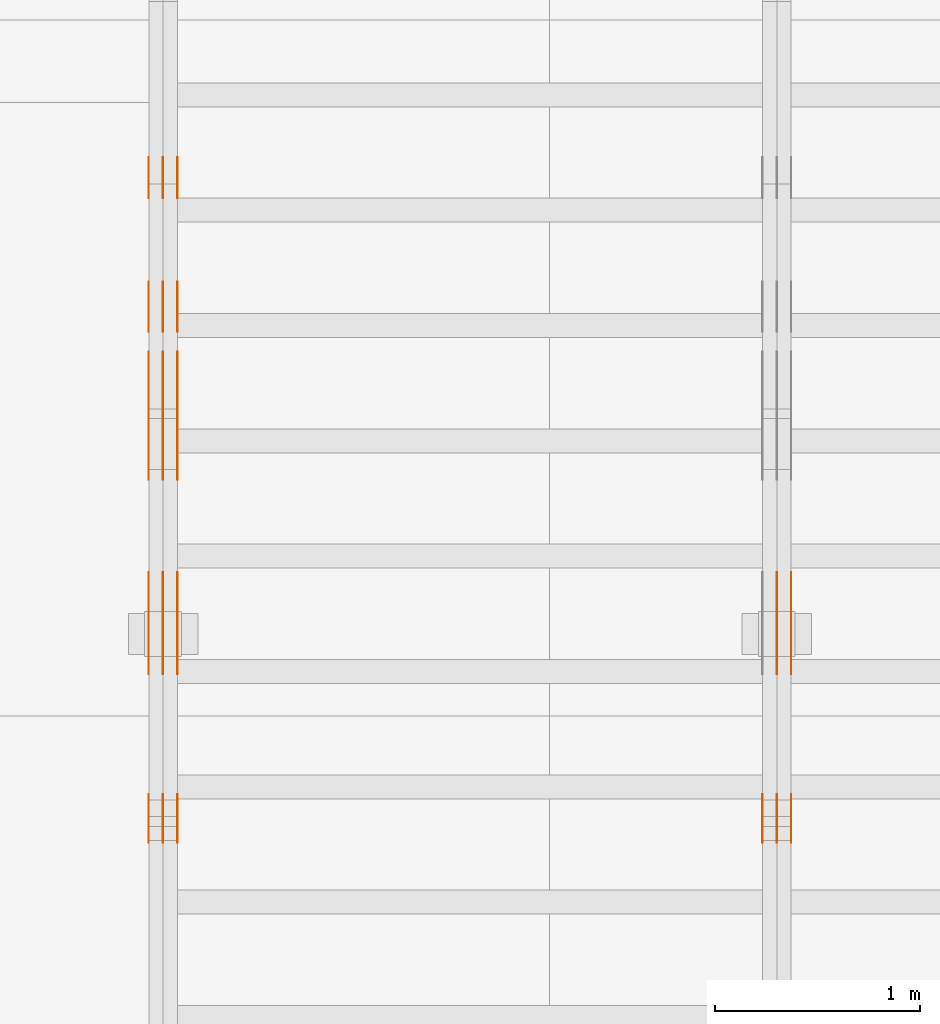
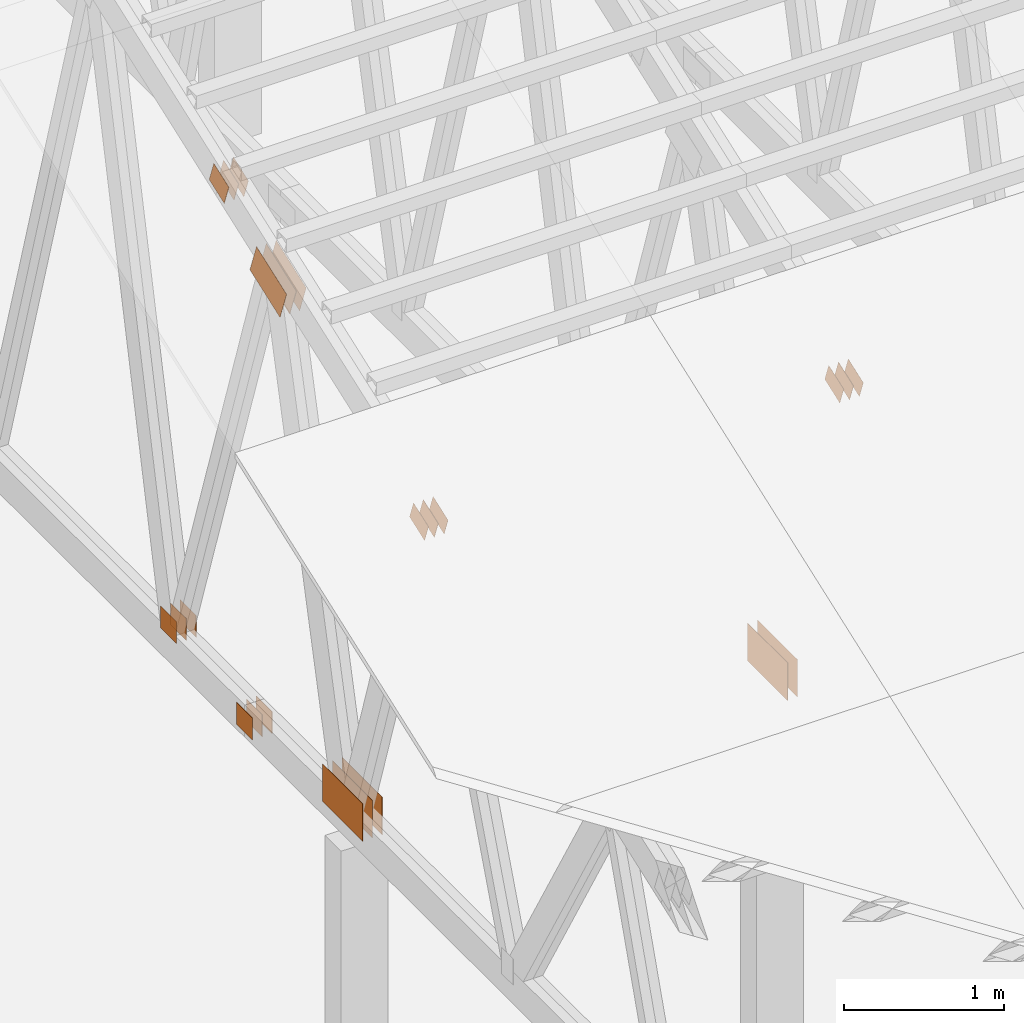
# One storey, part 76 of 189: 31 proxies.
"""IFC2X3 building model written with IfcOpenShell, lengths in millimetres."""

from ifc_helpers import new_model, entity, si_unit, converted_unit, derived_unit, direction, frame, frame_2d, origin, origin_2d_with_axis, place, context, subcontext, project, spatial, polyline, rectangle, outline, extrude, source, transform, mapped, material, type_object, type_shapes, element, save


model = new_model("IFC2X3")

# Units and contexts
model_context = context("Model", 3, precision=0.01, world=origin(), true_north=direction((6.12303176911189e-17, 1.0)))
body_context = subcontext(model_context, "Body", "Model", "MODEL_VIEW")
ifc_project = project(units=[si_unit("LENGTHUNIT", "METRE", prefix="MILLI"), si_unit("AREAUNIT", "SQUARE_METRE"), si_unit("VOLUMEUNIT", "CUBIC_METRE"), converted_unit("PLANEANGLEUNIT", "DEGREE", entity("IfcRatioMeasure", 0.0174532925199433), si_unit("PLANEANGLEUNIT", "RADIAN"), dimensions=[0, 0, 0, 0, 0, 0, 0]), si_unit("MASSUNIT", "GRAM", prefix="KILO"), derived_unit("MASSDENSITYUNIT", [(si_unit("MASSUNIT", "GRAM", prefix="KILO"), 1), (si_unit("LENGTHUNIT", "METRE"), -3)]), si_unit("TIMEUNIT", "SECOND"), si_unit("FREQUENCYUNIT", "HERTZ"), si_unit("THERMODYNAMICTEMPERATUREUNIT", "DEGREE_CELSIUS"), derived_unit("THERMALTRANSMITTANCEUNIT", [(si_unit("MASSUNIT", "GRAM", prefix="KILO"), 1), (si_unit("THERMODYNAMICTEMPERATUREUNIT", "KELVIN"), -1), (si_unit("TIMEUNIT", "SECOND"), -3)]), derived_unit("VOLUMETRICFLOWRATEUNIT", [(si_unit("LENGTHUNIT", "METRE"), 3), (si_unit("TIMEUNIT", "SECOND"), -1)]), si_unit("ELECTRICCURRENTUNIT", "AMPERE"), si_unit("ELECTRICVOLTAGEUNIT", "VOLT"), si_unit("POWERUNIT", "WATT"), si_unit("FORCEUNIT", "NEWTON"), si_unit("ILLUMINANCEUNIT", "LUX"), si_unit("LUMINOUSFLUXUNIT", "LUMEN"), si_unit("LUMINOUSINTENSITYUNIT", "CANDELA"), derived_unit("USERDEFINED", [(si_unit("MASSUNIT", "GRAM", prefix="KILO"), -1), (si_unit("LENGTHUNIT", "METRE"), -2), (si_unit("TIMEUNIT", "SECOND"), 3), (si_unit("LUMINOUSFLUXUNIT", "LUMEN"), 1)]), derived_unit("LINEARVELOCITYUNIT", [(si_unit("LENGTHUNIT", "METRE"), 1), (si_unit("TIMEUNIT", "SECOND"), -1)]), si_unit("PRESSUREUNIT", "PASCAL"), derived_unit("USERDEFINED", [(si_unit("LENGTHUNIT", "METRE"), -2), (si_unit("MASSUNIT", "GRAM", prefix="KILO"), 1), (si_unit("TIMEUNIT", "SECOND"), -2)])], contexts=[model_context])

# Site, building, storey
site_placement = place(None, origin())
site = spatial("IfcSite", under=ifc_project, at=site_placement, CompositionType="ELEMENT")
building_placement = place(site_placement, origin())
building = spatial("IfcBuilding", under=site, at=building_placement, CompositionType="ELEMENT")
storey_placement = place(building_placement, origin())
storey = spatial("IfcBuildingStorey", under=building, at=storey_placement, Name="Default", CompositionType="ELEMENT", Elevation=0.0)

# Proxies
ifc_material_1 = material(Name="IfcSurfaceStyle #28668")
building_element_proxy_type_1 = type_object("IfcBuildingElementProxyType", PredefinedType="NOTDEFINED", material=ifc_material_1)
shared_shape_1 = source(origin(), body_context, "Body", "SweptSolid", [
    extrude(rectangle(XDim=500.0, YDim=288.0, at=frame_2d((0.0, 1.4210854715202e-14), x_axis=(1.0, 0.0))), frame((250.000973740011, 144.0, 0.0), z_axis=(0.0, 0.0, 1.0), x_axis=(-1.0, 0.0, 0.0)), (0.0, 0.0, 1.0), 1.29999999999998),
])
type_shapes(building_element_proxy_type_1, [shared_shape_1])
proxy_1_placement = place(building_placement, frame((3336.3, 8551.90918250999, 389.0), z_axis=(-1.0, 0.0, 0.0), x_axis=(0.0, 1.0, 0.0)))
element("IfcBuildingElementProxy", 1, at=proxy_1_placement, inside=storey, type_object=building_element_proxy_type_1, material=ifc_material_1, context=body_context, shape_type="MappedRepresentation", body=[
    mapped(shared_shape_1, transform((0.0, 0.0, 0.0), scale=1.0)),
])
ifc_material_2 = material(Name="IfcSurfaceStyle #28611")
building_element_proxy_type_2 = type_object("IfcBuildingElementProxyType", PredefinedType="NOTDEFINED", material=ifc_material_2)
shared_shape_2 = source(origin(), body_context, "Body", "SweptSolid", [
    extrude(rectangle(XDim=500.0, YDim=288.0, at=frame_2d((0.0, 1.4210854715202e-14), x_axis=(1.0, 0.0))), frame((250.000973740011, 144.0, 0.0), z_axis=(0.0, 0.0, 1.0), x_axis=(-1.0, 0.0, 0.0)), (0.0, 0.0, 1.0), 1.29999999999997),
])
type_shapes(building_element_proxy_type_2, [shared_shape_2])
proxy_2_placement = place(building_placement, frame((3265.0, 8551.90918250999, 389.0), z_axis=(-1.0, 0.0, 0.0), x_axis=(0.0, 1.0, 0.0)))
element("IfcBuildingElementProxy", 2, at=proxy_2_placement, inside=storey, type_object=building_element_proxy_type_2, material=ifc_material_2, context=body_context, shape_type="MappedRepresentation", body=[
    mapped(shared_shape_2, transform((0.0, 0.0, 0.0), scale=1.0)),
])
ifc_material_3 = material(Name="IfcSurfaceStyle #28554")
building_element_proxy_type_3 = type_object("IfcBuildingElementProxyType", PredefinedType="NOTDEFINED", material=ifc_material_3)
shared_shape_3 = source(origin(), body_context, "Body", "SweptSolid", [
    extrude(rectangle(XDim=500.0, YDim=288.0, at=frame_2d((0.0, 1.4210854715202e-14), x_axis=(1.0, 0.0))), frame((250.000973740011, 144.0, 0.0), z_axis=(0.0, 0.0, 1.0), x_axis=(-1.0, 0.0, 0.0)), (0.0, 0.0, 1.0), 1.29999999999997),
])
type_shapes(building_element_proxy_type_3, [shared_shape_3])
proxy_3_placement = place(building_placement, frame((3266.3, 8551.90918250999, 389.0), z_axis=(-1.0, 0.0, 0.0), x_axis=(0.0, 1.0, 0.0)))
element("IfcBuildingElementProxy", 3, at=proxy_3_placement, inside=storey, type_object=building_element_proxy_type_3, material=ifc_material_3, context=body_context, shape_type="MappedRepresentation", body=[
    mapped(shared_shape_3, transform((0.0, 0.0, 0.0), scale=1.0)),
])
ifc_material_4 = material(Name="IfcSurfaceStyle #28440")
building_element_proxy_type_4 = type_object("IfcBuildingElementProxyType", PredefinedType="NOTDEFINED", material=ifc_material_4)
shared_shape_4 = source(origin(), body_context, "Body", "SweptSolid", [
    extrude(outline(polyline([(-100.00048713087, -72.0000025659129), (100.000394045495, -72.0000025659129), (99.9995694622958, 72.0000025659129), (-99.9994763769209, 72.0000025659128), (-100.00048713087, -72.0000025659129)])), frame((100.000394045495, 72.0000025659128, 0.0), z_axis=(0.0, 0.0, 1.0), x_axis=(-1.0, 0.0, 0.0)), (0.0, 0.0, 1.0), 1.3),
])
type_shapes(building_element_proxy_type_4, [shared_shape_4])
proxy_4_placement = place(building_placement, frame((3336.3, 7965.16887114408, 2936.19963864386), z_axis=(-1.0, 0.0, 0.0), x_axis=(0.0, -0.939692620785908, -0.342020143325669)))
element("IfcBuildingElementProxy", 4, at=proxy_4_placement, inside=storey, type_object=building_element_proxy_type_4, material=ifc_material_4, context=body_context, shape_type="MappedRepresentation", body=[
    mapped(shared_shape_4, transform((0.0, 0.0, 0.0), scale=1.0)),
])
ifc_material_5 = material(Name="IfcSurfaceStyle #28383")
building_element_proxy_type_5 = type_object("IfcBuildingElementProxyType", PredefinedType="NOTDEFINED", material=ifc_material_5)
shared_shape_5 = source(origin(), body_context, "Body", "SweptSolid", [
    extrude(outline(polyline([(-100.00048713087, -72.0000025659129), (100.000394045495, -72.0000025659129), (99.9995694622958, 72.0000025659129), (-99.9994763769209, 72.0000025659128), (-100.00048713087, -72.0000025659129)])), frame((100.000394045495, 72.0000025659128, 0.0), z_axis=(0.0, 0.0, 1.0), x_axis=(-1.0, 0.0, 0.0)), (0.0, 0.0, 1.0), 1.29999999999998),
])
type_shapes(building_element_proxy_type_5, [shared_shape_5])
proxy_5_placement = place(building_placement, frame((3265.0, 7965.16887114408, 2936.19963864386), z_axis=(-1.0, 0.0, 0.0), x_axis=(0.0, -0.939692620785908, -0.342020143325669)))
element("IfcBuildingElementProxy", 5, at=proxy_5_placement, inside=storey, type_object=building_element_proxy_type_5, material=ifc_material_5, context=body_context, shape_type="MappedRepresentation", body=[
    mapped(shared_shape_5, transform((0.0, 0.0, 0.0), scale=1.0)),
])
ifc_material_6 = material(Name="IfcSurfaceStyle #28326")
building_element_proxy_type_6 = type_object("IfcBuildingElementProxyType", PredefinedType="NOTDEFINED", material=ifc_material_6)
shared_shape_6 = source(origin(), body_context, "Body", "SweptSolid", [
    extrude(outline(polyline([(-100.00048713087, -72.0000025659129), (100.000394045495, -72.0000025659129), (99.9995694622958, 72.0000025659129), (-99.9994763769209, 72.0000025659128), (-100.00048713087, -72.0000025659129)])), frame((100.000394045495, 72.0000025659128, 0.0), z_axis=(0.0, 0.0, 1.0), x_axis=(-1.0, 0.0, 0.0)), (0.0, 0.0, 1.0), 1.29999999999998),
])
type_shapes(building_element_proxy_type_6, [shared_shape_6])
proxy_6_placement = place(building_placement, frame((3266.3, 7965.16887114408, 2936.19963864386), z_axis=(-1.0, 0.0, 0.0), x_axis=(0.0, -0.939692620785908, -0.342020143325669)))
element("IfcBuildingElementProxy", 6, at=proxy_6_placement, inside=storey, type_object=building_element_proxy_type_6, material=ifc_material_6, context=body_context, shape_type="MappedRepresentation", body=[
    mapped(shared_shape_6, transform((0.0, 0.0, 0.0), scale=1.0)),
])
ifc_material_7 = material(Name="IfcSurfaceStyle #28269")
building_element_proxy_type_7 = type_object("IfcBuildingElementProxyType", PredefinedType="NOTDEFINED", material=ifc_material_7)
shared_shape_7 = source(origin(), body_context, "Body", "SweptSolid", [
    extrude(outline(polyline([(-100.00048713087, -72.0000025659129), (100.000394045495, -72.0000025659129), (99.9995694622958, 72.0000025659129), (-99.9994763769209, 72.0000025659128), (-100.00048713087, -72.0000025659129)])), frame((100.000394045495, 72.0000025659128, 0.0), z_axis=(0.0, 0.0, 1.0), x_axis=(-1.0, 0.0, 0.0)), (0.0, 0.0, 1.0), 1.29999999999999),
])
type_shapes(building_element_proxy_type_7, [shared_shape_7])
proxy_7_placement = place(building_placement, frame((3195.0, 7965.16887114408, 2936.19963864386), z_axis=(-1.0, 0.0, 0.0), x_axis=(0.0, -0.939692620785908, -0.342020143325669)))
element("IfcBuildingElementProxy", 7, at=proxy_7_placement, inside=storey, type_object=building_element_proxy_type_7, material=ifc_material_7, context=body_context, shape_type="MappedRepresentation", body=[
    mapped(shared_shape_7, transform((0.0, 0.0, 0.0), scale=1.0)),
])
ifc_material_8 = material(Name="IfcSurfaceStyle #13787")
building_element_proxy_type_8 = type_object("IfcBuildingElementProxyType", PredefinedType="NOTDEFINED", material=ifc_material_8)
shared_shape_8 = source(origin(), body_context, "Body", "SweptSolid", [
    extrude(rectangle(XDim=200.0, YDim=168.0, at=origin_2d_with_axis()), frame((100.000765376775, 84.0, 0.0), z_axis=(0.0, 0.0, 1.0), x_axis=(-1.0, 0.0, 0.0)), (0.0, 0.0, 1.0), 1.3),
])
type_shapes(building_element_proxy_type_8, [shared_shape_8])
proxy_8_placement = place(building_placement, frame((336.3, 10880.1574377482, 365.0), z_axis=(-1.0, 0.0, 0.0), x_axis=(0.0, 1.0, 0.0)))
element("IfcBuildingElementProxy", 8, at=proxy_8_placement, inside=storey, type_object=building_element_proxy_type_8, material=ifc_material_8, context=body_context, shape_type="MappedRepresentation", body=[
    mapped(shared_shape_8, transform((0.0, 0.0, 0.0), scale=1.0)),
])
ifc_material_9 = material(Name="IfcSurfaceStyle #13730")
building_element_proxy_type_9 = type_object("IfcBuildingElementProxyType", PredefinedType="NOTDEFINED", material=ifc_material_9)
shared_shape_9 = source(origin(), body_context, "Body", "SweptSolid", [
    extrude(rectangle(XDim=200.0, YDim=168.0, at=origin_2d_with_axis()), frame((100.000765376775, 84.0, 0.0), z_axis=(0.0, 0.0, 1.0), x_axis=(-1.0, 0.0, 0.0)), (0.0, 0.0, 1.0), 1.29999999999998),
])
type_shapes(building_element_proxy_type_9, [shared_shape_9])
proxy_9_placement = place(building_placement, frame((265.0, 10880.1574377482, 365.0), z_axis=(-1.0, 0.0, 0.0), x_axis=(0.0, 1.0, 0.0)))
element("IfcBuildingElementProxy", 9, at=proxy_9_placement, inside=storey, type_object=building_element_proxy_type_9, material=ifc_material_9, context=body_context, shape_type="MappedRepresentation", body=[
    mapped(shared_shape_9, transform((0.0, 0.0, 0.0), scale=1.0)),
])
ifc_material_10 = material(Name="IfcSurfaceStyle #13673")
building_element_proxy_type_10 = type_object("IfcBuildingElementProxyType", PredefinedType="NOTDEFINED", material=ifc_material_10)
shared_shape_10 = source(origin(), body_context, "Body", "SweptSolid", [
    extrude(rectangle(XDim=200.0, YDim=168.0, at=origin_2d_with_axis()), frame((100.000765376775, 84.0, 0.0), z_axis=(0.0, 0.0, 1.0), x_axis=(-1.0, 0.0, 0.0)), (0.0, 0.0, 1.0), 1.29999999999998),
])
type_shapes(building_element_proxy_type_10, [shared_shape_10])
proxy_10_placement = place(building_placement, frame((266.3, 10880.1574377482, 365.0), z_axis=(-1.0, 0.0, 0.0), x_axis=(0.0, 1.0, 0.0)))
element("IfcBuildingElementProxy", 10, at=proxy_10_placement, inside=storey, type_object=building_element_proxy_type_10, material=ifc_material_10, context=body_context, shape_type="MappedRepresentation", body=[
    mapped(shared_shape_10, transform((0.0, 0.0, 0.0), scale=1.0)),
])
ifc_material_11 = material(Name="IfcSurfaceStyle #13616")
building_element_proxy_type_11 = type_object("IfcBuildingElementProxyType", PredefinedType="NOTDEFINED", material=ifc_material_11)
shared_shape_11 = source(origin(), body_context, "Body", "SweptSolid", [
    extrude(rectangle(XDim=200.0, YDim=168.0, at=origin_2d_with_axis()), frame((100.000765376775, 84.0, 0.0), z_axis=(0.0, 0.0, 1.0), x_axis=(-1.0, 0.0, 0.0)), (0.0, 0.0, 1.0), 1.29999999999999),
])
type_shapes(building_element_proxy_type_11, [shared_shape_11])
proxy_11_placement = place(building_placement, frame((195.0, 10880.1574377482, 365.0), z_axis=(-1.0, 0.0, 0.0), x_axis=(0.0, 1.0, 0.0)))
element("IfcBuildingElementProxy", 11, at=proxy_11_placement, inside=storey, type_object=building_element_proxy_type_11, material=ifc_material_11, context=body_context, shape_type="MappedRepresentation", body=[
    mapped(shared_shape_11, transform((0.0, 0.0, 0.0), scale=1.0)),
])
ifc_material_12 = material(Name="IfcSurfaceStyle #13559")
building_element_proxy_type_12 = type_object("IfcBuildingElementProxyType", PredefinedType="NOTDEFINED", material=ifc_material_12)
shared_shape_12 = source(origin(), body_context, "Body", "SweptSolid", [
    extrude(outline(polyline([(-199.999582244654, -119.99984375717), (200.000344770932, -119.99984375717), (199.999582244655, 119.99984375717), (-200.000344770934, 119.99984375717), (-199.999582244654, -119.99984375717)])), frame((200.000344770932, 120.0000091947, 0.0), z_axis=(0.0, 0.0, 1.0), x_axis=(-1.0, 0.0, 0.0)), (0.0, 0.0, 1.0), 1.29999999999999),
])
type_shapes(building_element_proxy_type_12, [shared_shape_12])
proxy_12_placement = place(building_placement, frame((336.3, 9961.90704972973, 3612.2451494258), z_axis=(-1.0, 0.0, 0.0), x_axis=(0.0, -0.939692620785908, -0.342020143325669)))
element("IfcBuildingElementProxy", 12, at=proxy_12_placement, inside=storey, type_object=building_element_proxy_type_12, material=ifc_material_12, context=body_context, shape_type="MappedRepresentation", body=[
    mapped(shared_shape_12, transform((0.0, 0.0, 0.0), scale=1.0)),
])
ifc_material_13 = material(Name="IfcSurfaceStyle #13502")
building_element_proxy_type_13 = type_object("IfcBuildingElementProxyType", PredefinedType="NOTDEFINED", material=ifc_material_13)
shared_shape_13 = source(origin(), body_context, "Body", "SweptSolid", [
    extrude(outline(polyline([(-199.999582244654, -119.99984375717), (200.000344770932, -119.99984375717), (199.999582244655, 119.99984375717), (-200.000344770934, 119.99984375717), (-199.999582244654, -119.99984375717)])), frame((200.000344770932, 120.0000091947, 0.0), z_axis=(0.0, 0.0, 1.0), x_axis=(-1.0, 0.0, 0.0)), (0.0, 0.0, 1.0), 1.29999999999997),
])
type_shapes(building_element_proxy_type_13, [shared_shape_13])
proxy_13_placement = place(building_placement, frame((265.0, 9961.90704972973, 3612.2451494258), z_axis=(-1.0, 0.0, 0.0), x_axis=(0.0, -0.939692620785908, -0.342020143325669)))
element("IfcBuildingElementProxy", 13, at=proxy_13_placement, inside=storey, type_object=building_element_proxy_type_13, material=ifc_material_13, context=body_context, shape_type="MappedRepresentation", body=[
    mapped(shared_shape_13, transform((0.0, 0.0, 0.0), scale=1.0)),
])
ifc_material_14 = material(Name="IfcSurfaceStyle #13445")
building_element_proxy_type_14 = type_object("IfcBuildingElementProxyType", PredefinedType="NOTDEFINED", material=ifc_material_14)
shared_shape_14 = source(origin(), body_context, "Body", "SweptSolid", [
    extrude(outline(polyline([(-199.999582244654, -119.99984375717), (200.000344770932, -119.99984375717), (199.999582244655, 119.99984375717), (-200.000344770934, 119.99984375717), (-199.999582244654, -119.99984375717)])), frame((200.000344770932, 120.0000091947, 0.0), z_axis=(0.0, 0.0, 1.0), x_axis=(-1.0, 0.0, 0.0)), (0.0, 0.0, 1.0), 1.29999999999997),
])
type_shapes(building_element_proxy_type_14, [shared_shape_14])
proxy_14_placement = place(building_placement, frame((266.3, 9961.90704972973, 3612.2451494258), z_axis=(-1.0, 0.0, 0.0), x_axis=(0.0, -0.939692620785908, -0.342020143325669)))
element("IfcBuildingElementProxy", 14, at=proxy_14_placement, inside=storey, type_object=building_element_proxy_type_14, material=ifc_material_14, context=body_context, shape_type="MappedRepresentation", body=[
    mapped(shared_shape_14, transform((0.0, 0.0, 0.0), scale=1.0)),
])
ifc_material_15 = material(Name="IfcSurfaceStyle #13388")
building_element_proxy_type_15 = type_object("IfcBuildingElementProxyType", PredefinedType="NOTDEFINED", material=ifc_material_15)
shared_shape_15 = source(origin(), body_context, "Body", "SweptSolid", [
    extrude(outline(polyline([(-199.999582244654, -119.99984375717), (200.000344770932, -119.99984375717), (199.999582244655, 119.99984375717), (-200.000344770934, 119.99984375717), (-199.999582244654, -119.99984375717)])), frame((200.000344770932, 120.0000091947, 0.0), z_axis=(0.0, 0.0, 1.0), x_axis=(-1.0, 0.0, 0.0)), (0.0, 0.0, 1.0), 1.29999999999998),
])
type_shapes(building_element_proxy_type_15, [shared_shape_15])
proxy_15_placement = place(building_placement, frame((195.0, 9961.90704972973, 3612.2451494258), z_axis=(-1.0, 0.0, 0.0), x_axis=(0.0, -0.939692620785908, -0.342020143325669)))
element("IfcBuildingElementProxy", 15, at=proxy_15_placement, inside=storey, type_object=building_element_proxy_type_15, material=ifc_material_15, context=body_context, shape_type="MappedRepresentation", body=[
    mapped(shared_shape_15, transform((0.0, 0.0, 0.0), scale=1.0)),
])
ifc_material_16 = material(Name="IfcSurfaceStyle #12875")
building_element_proxy_type_16 = type_object("IfcBuildingElementProxyType", PredefinedType="NOTDEFINED", material=ifc_material_16)
shared_shape_16 = source(origin(), body_context, "Body", "SweptSolid", [
    extrude(rectangle(XDim=500.0, YDim=288.0, at=frame_2d((0.0, 1.4210854715202e-14), x_axis=(1.0, 0.0))), frame((250.000973740011, 144.0, 0.0), z_axis=(0.0, 0.0, 1.0), x_axis=(-1.0, 0.0, 0.0)), (0.0, 0.0, 1.0), 1.29999999999998),
])
type_shapes(building_element_proxy_type_16, [shared_shape_16])
proxy_16_placement = place(building_placement, frame((336.3, 8551.90918250999, 389.0), z_axis=(-1.0, 0.0, 0.0), x_axis=(0.0, 1.0, 0.0)))
element("IfcBuildingElementProxy", 16, at=proxy_16_placement, inside=storey, type_object=building_element_proxy_type_16, material=ifc_material_16, context=body_context, shape_type="MappedRepresentation", body=[
    mapped(shared_shape_16, transform((0.0, 0.0, 0.0), scale=1.0)),
])
ifc_material_17 = material(Name="IfcSurfaceStyle #12818")
building_element_proxy_type_17 = type_object("IfcBuildingElementProxyType", PredefinedType="NOTDEFINED", material=ifc_material_17)
shared_shape_17 = source(origin(), body_context, "Body", "SweptSolid", [
    extrude(rectangle(XDim=500.0, YDim=288.0, at=frame_2d((0.0, 1.4210854715202e-14), x_axis=(1.0, 0.0))), frame((250.000973740011, 144.0, 0.0), z_axis=(0.0, 0.0, 1.0), x_axis=(-1.0, 0.0, 0.0)), (0.0, 0.0, 1.0), 1.29999999999997),
])
type_shapes(building_element_proxy_type_17, [shared_shape_17])
proxy_17_placement = place(building_placement, frame((265.0, 8551.90918250999, 389.0), z_axis=(-1.0, 0.0, 0.0), x_axis=(0.0, 1.0, 0.0)))
element("IfcBuildingElementProxy", 17, at=proxy_17_placement, inside=storey, type_object=building_element_proxy_type_17, material=ifc_material_17, context=body_context, shape_type="MappedRepresentation", body=[
    mapped(shared_shape_17, transform((0.0, 0.0, 0.0), scale=1.0)),
])
ifc_material_18 = material(Name="IfcSurfaceStyle #12761")
building_element_proxy_type_18 = type_object("IfcBuildingElementProxyType", PredefinedType="NOTDEFINED", material=ifc_material_18)
shared_shape_18 = source(origin(), body_context, "Body", "SweptSolid", [
    extrude(rectangle(XDim=500.0, YDim=288.0, at=frame_2d((0.0, 1.4210854715202e-14), x_axis=(1.0, 0.0))), frame((250.000973740011, 144.0, 0.0), z_axis=(0.0, 0.0, 1.0), x_axis=(-1.0, 0.0, 0.0)), (0.0, 0.0, 1.0), 1.29999999999997),
])
type_shapes(building_element_proxy_type_18, [shared_shape_18])
proxy_18_placement = place(building_placement, frame((266.3, 8551.90918250999, 389.0), z_axis=(-1.0, 0.0, 0.0), x_axis=(0.0, 1.0, 0.0)))
element("IfcBuildingElementProxy", 18, at=proxy_18_placement, inside=storey, type_object=building_element_proxy_type_18, material=ifc_material_18, context=body_context, shape_type="MappedRepresentation", body=[
    mapped(shared_shape_18, transform((0.0, 0.0, 0.0), scale=1.0)),
])
ifc_material_19 = material(Name="IfcSurfaceStyle #12704")
building_element_proxy_type_19 = type_object("IfcBuildingElementProxyType", PredefinedType="NOTDEFINED", material=ifc_material_19)
shared_shape_19 = source(origin(), body_context, "Body", "SweptSolid", [
    extrude(rectangle(XDim=500.0, YDim=288.0, at=frame_2d((0.0, 1.4210854715202e-14), x_axis=(1.0, 0.0))), frame((250.000973740011, 144.0, 0.0), z_axis=(0.0, 0.0, 1.0), x_axis=(-1.0, 0.0, 0.0)), (0.0, 0.0, 1.0), 1.29999999999997),
])
type_shapes(building_element_proxy_type_19, [shared_shape_19])
proxy_19_placement = place(building_placement, frame((195.0, 8551.90918250999, 389.0), z_axis=(-1.0, 0.0, 0.0), x_axis=(0.0, 1.0, 0.0)))
element("IfcBuildingElementProxy", 19, at=proxy_19_placement, inside=storey, type_object=building_element_proxy_type_19, material=ifc_material_19, context=body_context, shape_type="MappedRepresentation", body=[
    mapped(shared_shape_19, transform((0.0, 0.0, 0.0), scale=1.0)),
])
ifc_material_20 = material(Name="IfcSurfaceStyle #12647")
building_element_proxy_type_20 = type_object("IfcBuildingElementProxyType", PredefinedType="NOTDEFINED", material=ifc_material_20)
shared_shape_20 = source(origin(), body_context, "Body", "SweptSolid", [
    extrude(outline(polyline([(-100.00048713087, -72.0000025659129), (100.000394045495, -72.0000025659129), (99.9995694622958, 72.0000025659129), (-99.9994763769209, 72.0000025659128), (-100.00048713087, -72.0000025659129)])), frame((100.000394045495, 72.0000025659128, 0.0), z_axis=(0.0, 0.0, 1.0), x_axis=(-1.0, 0.0, 0.0)), (0.0, 0.0, 1.0), 1.3),
])
type_shapes(building_element_proxy_type_20, [shared_shape_20])
proxy_20_placement = place(building_placement, frame((336.3, 7965.16887114408, 2936.19963864386), z_axis=(-1.0, 0.0, 0.0), x_axis=(0.0, -0.939692620785908, -0.342020143325669)))
element("IfcBuildingElementProxy", 20, at=proxy_20_placement, inside=storey, type_object=building_element_proxy_type_20, material=ifc_material_20, context=body_context, shape_type="MappedRepresentation", body=[
    mapped(shared_shape_20, transform((0.0, 0.0, 0.0), scale=1.0)),
])
ifc_material_21 = material(Name="IfcSurfaceStyle #12590")
building_element_proxy_type_21 = type_object("IfcBuildingElementProxyType", PredefinedType="NOTDEFINED", material=ifc_material_21)
shared_shape_21 = source(origin(), body_context, "Body", "SweptSolid", [
    extrude(outline(polyline([(-100.00048713087, -72.0000025659129), (100.000394045495, -72.0000025659129), (99.9995694622958, 72.0000025659129), (-99.9994763769209, 72.0000025659128), (-100.00048713087, -72.0000025659129)])), frame((100.000394045495, 72.0000025659128, 0.0), z_axis=(0.0, 0.0, 1.0), x_axis=(-1.0, 0.0, 0.0)), (0.0, 0.0, 1.0), 1.29999999999998),
])
type_shapes(building_element_proxy_type_21, [shared_shape_21])
proxy_21_placement = place(building_placement, frame((265.0, 7965.16887114408, 2936.19963864386), z_axis=(-1.0, 0.0, 0.0), x_axis=(0.0, -0.939692620785908, -0.342020143325669)))
element("IfcBuildingElementProxy", 21, at=proxy_21_placement, inside=storey, type_object=building_element_proxy_type_21, material=ifc_material_21, context=body_context, shape_type="MappedRepresentation", body=[
    mapped(shared_shape_21, transform((0.0, 0.0, 0.0), scale=1.0)),
])
ifc_material_22 = material(Name="IfcSurfaceStyle #12533")
building_element_proxy_type_22 = type_object("IfcBuildingElementProxyType", PredefinedType="NOTDEFINED", material=ifc_material_22)
shared_shape_22 = source(origin(), body_context, "Body", "SweptSolid", [
    extrude(outline(polyline([(-100.00048713087, -72.0000025659129), (100.000394045495, -72.0000025659129), (99.9995694622958, 72.0000025659129), (-99.9994763769209, 72.0000025659128), (-100.00048713087, -72.0000025659129)])), frame((100.000394045495, 72.0000025659128, 0.0), z_axis=(0.0, 0.0, 1.0), x_axis=(-1.0, 0.0, 0.0)), (0.0, 0.0, 1.0), 1.29999999999998),
])
type_shapes(building_element_proxy_type_22, [shared_shape_22])
proxy_22_placement = place(building_placement, frame((266.3, 7965.16887114408, 2936.19963864386), z_axis=(-1.0, 0.0, 0.0), x_axis=(0.0, -0.939692620785908, -0.342020143325669)))
element("IfcBuildingElementProxy", 22, at=proxy_22_placement, inside=storey, type_object=building_element_proxy_type_22, material=ifc_material_22, context=body_context, shape_type="MappedRepresentation", body=[
    mapped(shared_shape_22, transform((0.0, 0.0, 0.0), scale=1.0)),
])
ifc_material_23 = material(Name="IfcSurfaceStyle #12476")
building_element_proxy_type_23 = type_object("IfcBuildingElementProxyType", PredefinedType="NOTDEFINED", material=ifc_material_23)
shared_shape_23 = source(origin(), body_context, "Body", "SweptSolid", [
    extrude(outline(polyline([(-100.00048713087, -72.0000025659129), (100.000394045495, -72.0000025659129), (99.9995694622958, 72.0000025659129), (-99.9994763769209, 72.0000025659128), (-100.00048713087, -72.0000025659129)])), frame((100.000394045495, 72.0000025659128, 0.0), z_axis=(0.0, 0.0, 1.0), x_axis=(-1.0, 0.0, 0.0)), (0.0, 0.0, 1.0), 1.29999999999999),
])
type_shapes(building_element_proxy_type_23, [shared_shape_23])
proxy_23_placement = place(building_placement, frame((195.0, 7965.16887114408, 2936.19963864386), z_axis=(-1.0, 0.0, 0.0), x_axis=(0.0, -0.939692620785908, -0.342020143325669)))
element("IfcBuildingElementProxy", 23, at=proxy_23_placement, inside=storey, type_object=building_element_proxy_type_23, material=ifc_material_23, context=body_context, shape_type="MappedRepresentation", body=[
    mapped(shared_shape_23, transform((0.0, 0.0, 0.0), scale=1.0)),
])
ifc_material_24 = material(Name="IfcSurfaceStyle #7235")
building_element_proxy_type_24 = type_object("IfcBuildingElementProxyType", PredefinedType="NOTDEFINED", material=ifc_material_24)
shared_shape_24 = source(origin(), body_context, "Body", "SweptSolid", [
    extrude(rectangle(XDim=200.0, YDim=168.0, at=origin_2d_with_axis()), frame((100.0, 84.0, 0.0), z_axis=(0.0, 0.0, 1.0), x_axis=(-1.0, 0.0, 0.0)), (0.0, 0.0, 1.0), 1.3),
])
type_shapes(building_element_proxy_type_24, [shared_shape_24])
proxy_24_placement = place(building_placement, frame((336.3, 9929.23046875, 206.5), z_axis=(-1.0, 0.0, 0.0), x_axis=(0.0, 1.0, 0.0)))
element("IfcBuildingElementProxy", 24, at=proxy_24_placement, inside=storey, type_object=building_element_proxy_type_24, material=ifc_material_24, context=body_context, shape_type="MappedRepresentation", body=[
    mapped(shared_shape_24, transform((0.0, 0.0, 0.0), scale=1.0)),
])
ifc_material_25 = material(Name="IfcSurfaceStyle #7178")
building_element_proxy_type_25 = type_object("IfcBuildingElementProxyType", PredefinedType="NOTDEFINED", material=ifc_material_25)
shared_shape_25 = source(origin(), body_context, "Body", "SweptSolid", [
    extrude(rectangle(XDim=200.0, YDim=168.0, at=origin_2d_with_axis()), frame((100.0, 84.0, 0.0), z_axis=(0.0, 0.0, 1.0), x_axis=(-1.0, 0.0, 0.0)), (0.0, 0.0, 1.0), 1.29999999999998),
])
type_shapes(building_element_proxy_type_25, [shared_shape_25])
proxy_25_placement = place(building_placement, frame((265.0, 9929.23046875, 206.5), z_axis=(-1.0, 0.0, 0.0), x_axis=(0.0, 1.0, 0.0)))
element("IfcBuildingElementProxy", 25, at=proxy_25_placement, inside=storey, type_object=building_element_proxy_type_25, material=ifc_material_25, context=body_context, shape_type="MappedRepresentation", body=[
    mapped(shared_shape_25, transform((0.0, 0.0, 0.0), scale=1.0)),
])
ifc_material_26 = material(Name="IfcSurfaceStyle #7121")
building_element_proxy_type_26 = type_object("IfcBuildingElementProxyType", PredefinedType="NOTDEFINED", material=ifc_material_26)
shared_shape_26 = source(origin(), body_context, "Body", "SweptSolid", [
    extrude(rectangle(XDim=200.0, YDim=168.0, at=origin_2d_with_axis()), frame((100.0, 84.0, 0.0), z_axis=(0.0, 0.0, 1.0), x_axis=(-1.0, 0.0, 0.0)), (0.0, 0.0, 1.0), 1.29999999999998),
])
type_shapes(building_element_proxy_type_26, [shared_shape_26])
proxy_26_placement = place(building_placement, frame((266.3, 9929.23046875, 206.5), z_axis=(-1.0, 0.0, 0.0), x_axis=(0.0, 1.0, 0.0)))
element("IfcBuildingElementProxy", 26, at=proxy_26_placement, inside=storey, type_object=building_element_proxy_type_26, material=ifc_material_26, context=body_context, shape_type="MappedRepresentation", body=[
    mapped(shared_shape_26, transform((0.0, 0.0, 0.0), scale=1.0)),
])
ifc_material_27 = material(Name="IfcSurfaceStyle #7064")
building_element_proxy_type_27 = type_object("IfcBuildingElementProxyType", PredefinedType="NOTDEFINED", material=ifc_material_27)
shared_shape_27 = source(origin(), body_context, "Body", "SweptSolid", [
    extrude(rectangle(XDim=200.0, YDim=168.0, at=origin_2d_with_axis()), frame((100.0, 84.0, 0.0), z_axis=(0.0, 0.0, 1.0), x_axis=(-1.0, 0.0, 0.0)), (0.0, 0.0, 1.0), 1.29999999999999),
])
type_shapes(building_element_proxy_type_27, [shared_shape_27])
proxy_27_placement = place(building_placement, frame((195.0, 9929.23046875, 206.5), z_axis=(-1.0, 0.0, 0.0), x_axis=(0.0, 1.0, 0.0)))
element("IfcBuildingElementProxy", 27, at=proxy_27_placement, inside=storey, type_object=building_element_proxy_type_27, material=ifc_material_27, context=body_context, shape_type="MappedRepresentation", body=[
    mapped(shared_shape_27, transform((0.0, 0.0, 0.0), scale=1.0)),
])
ifc_material_28 = material(Name="IfcSurfaceStyle #6155")
building_element_proxy_type_28 = type_object("IfcBuildingElementProxyType", PredefinedType="NOTDEFINED", material=ifc_material_28)
shared_shape_28 = source(origin(), body_context, "Body", "SweptSolid", [
    extrude(outline(polyline([(-100.00072430513, -84.0000258989549), (100.000156871239, -84.0000258989549), (99.9997648860508, 84.0000258989549), (-99.9991974521591, 84.0000258989548), (-100.00072430513, -84.0000258989549)])), frame((100.000156871239, 84.0000258989548, 0.0), z_axis=(0.0, 0.0, 1.0), x_axis=(-1.0, 0.0, 0.0)), (0.0, 0.0, 1.0), 1.3),
])
type_shapes(building_element_proxy_type_28, [shared_shape_28])
proxy_28_placement = place(building_placement, frame((336.3, 10226.4409888304, 4081.14941482552), z_axis=(-1.0, 0.0, 0.0), x_axis=(0.0, 0.939692620785908, 0.342020143325669)))
element("IfcBuildingElementProxy", 28, at=proxy_28_placement, inside=storey, type_object=building_element_proxy_type_28, material=ifc_material_28, context=body_context, shape_type="MappedRepresentation", body=[
    mapped(shared_shape_28, transform((0.0, 0.0, 0.0), scale=1.0)),
])
ifc_material_29 = material(Name="IfcSurfaceStyle #6098")
building_element_proxy_type_29 = type_object("IfcBuildingElementProxyType", PredefinedType="NOTDEFINED", material=ifc_material_29)
shared_shape_29 = source(origin(), body_context, "Body", "SweptSolid", [
    extrude(outline(polyline([(-100.00072430513, -84.0000258989549), (100.000156871239, -84.0000258989549), (99.9997648860508, 84.0000258989549), (-99.9991974521591, 84.0000258989548), (-100.00072430513, -84.0000258989549)])), frame((100.000156871239, 84.0000258989548, 0.0), z_axis=(0.0, 0.0, 1.0), x_axis=(-1.0, 0.0, 0.0)), (0.0, 0.0, 1.0), 1.29999999999998),
])
type_shapes(building_element_proxy_type_29, [shared_shape_29])
proxy_29_placement = place(building_placement, frame((265.0, 10226.4409888304, 4081.14941482552), z_axis=(-1.0, 0.0, 0.0), x_axis=(0.0, 0.939692620785908, 0.342020143325669)))
element("IfcBuildingElementProxy", 29, at=proxy_29_placement, inside=storey, type_object=building_element_proxy_type_29, material=ifc_material_29, context=body_context, shape_type="MappedRepresentation", body=[
    mapped(shared_shape_29, transform((0.0, 0.0, 0.0), scale=1.0)),
])
ifc_material_30 = material(Name="IfcSurfaceStyle #6041")
building_element_proxy_type_30 = type_object("IfcBuildingElementProxyType", PredefinedType="NOTDEFINED", material=ifc_material_30)
shared_shape_30 = source(origin(), body_context, "Body", "SweptSolid", [
    extrude(outline(polyline([(-100.00072430513, -84.0000258989549), (100.000156871239, -84.0000258989549), (99.9997648860508, 84.0000258989549), (-99.9991974521591, 84.0000258989548), (-100.00072430513, -84.0000258989549)])), frame((100.000156871239, 84.0000258989548, 0.0), z_axis=(0.0, 0.0, 1.0), x_axis=(-1.0, 0.0, 0.0)), (0.0, 0.0, 1.0), 1.29999999999998),
])
type_shapes(building_element_proxy_type_30, [shared_shape_30])
proxy_30_placement = place(building_placement, frame((266.3, 10226.4409888304, 4081.14941482552), z_axis=(-1.0, 0.0, 0.0), x_axis=(0.0, 0.939692620785908, 0.342020143325669)))
element("IfcBuildingElementProxy", 30, at=proxy_30_placement, inside=storey, type_object=building_element_proxy_type_30, material=ifc_material_30, context=body_context, shape_type="MappedRepresentation", body=[
    mapped(shared_shape_30, transform((0.0, 0.0, 0.0), scale=1.0)),
])
ifc_material_31 = material(Name="IfcSurfaceStyle #5984")
building_element_proxy_type_31 = type_object("IfcBuildingElementProxyType", PredefinedType="NOTDEFINED", material=ifc_material_31)
shared_shape_31 = source(origin(), body_context, "Body", "SweptSolid", [
    extrude(outline(polyline([(-100.00072430513, -84.0000258989549), (100.000156871239, -84.0000258989549), (99.9997648860508, 84.0000258989549), (-99.9991974521591, 84.0000258989548), (-100.00072430513, -84.0000258989549)])), frame((100.000156871239, 84.0000258989548, 0.0), z_axis=(0.0, 0.0, 1.0), x_axis=(-1.0, 0.0, 0.0)), (0.0, 0.0, 1.0), 1.29999999999999),
])
type_shapes(building_element_proxy_type_31, [shared_shape_31])
proxy_31_placement = place(building_placement, frame((195.0, 10226.4409888304, 4081.14941482552), z_axis=(-1.0, 0.0, 0.0), x_axis=(0.0, 0.939692620785908, 0.342020143325669)))
element("IfcBuildingElementProxy", 31, at=proxy_31_placement, inside=storey, type_object=building_element_proxy_type_31, material=ifc_material_31, context=body_context, shape_type="MappedRepresentation", body=[
    mapped(shared_shape_31, transform((0.0, 0.0, 0.0), scale=1.0)),
])

save(model, "model.ifc")
